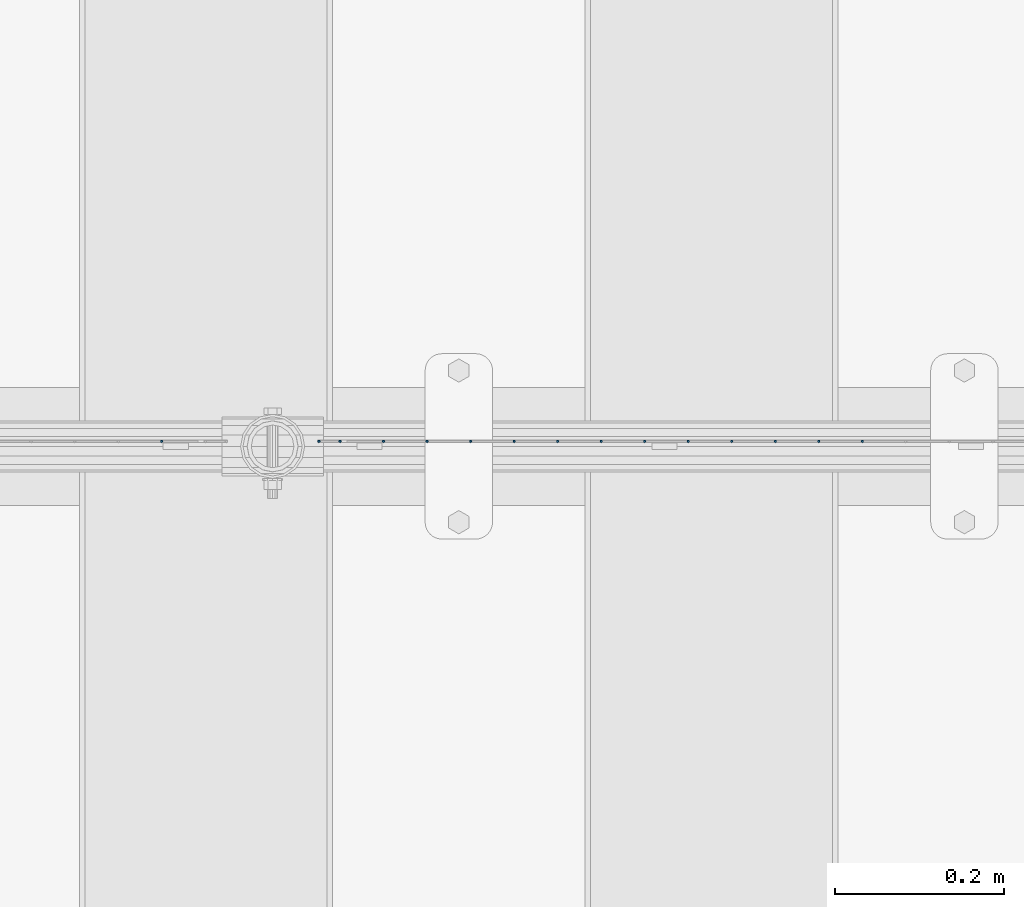
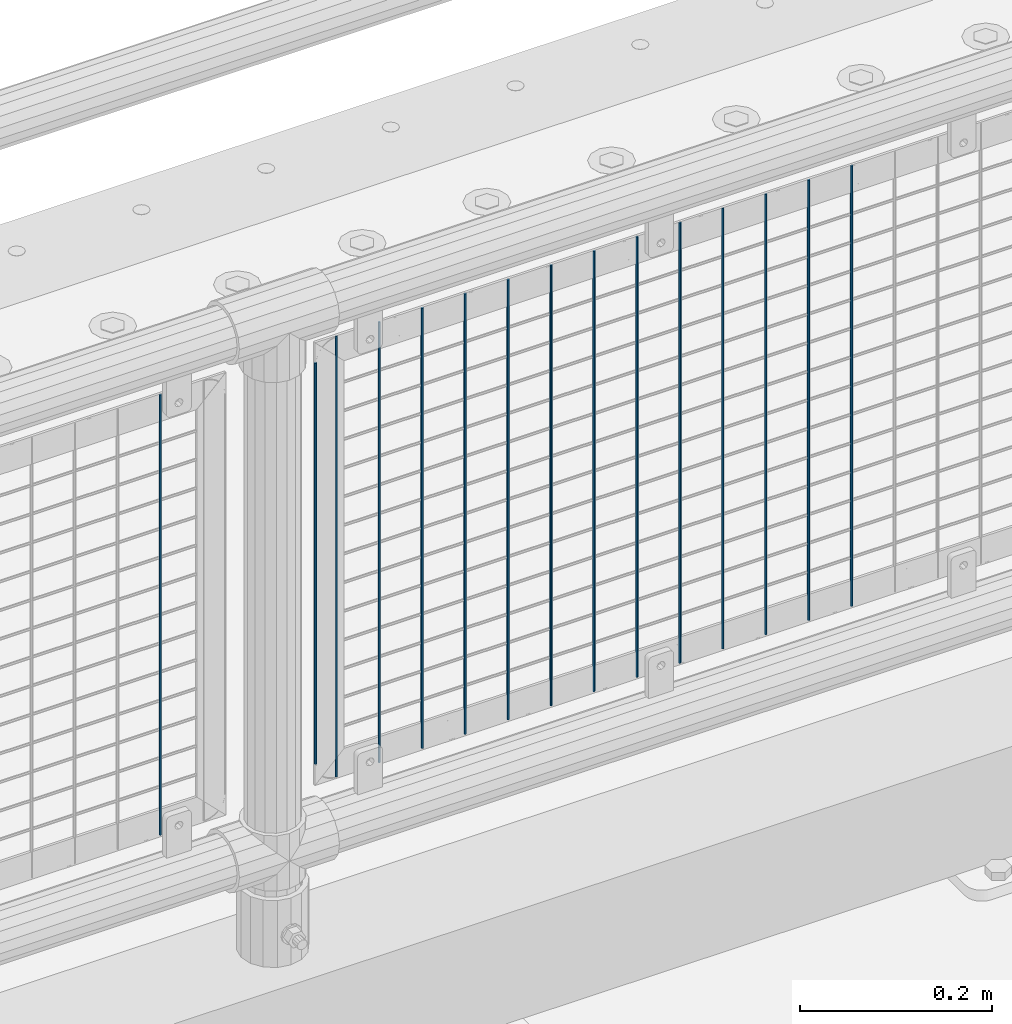
# One storey, part 67 of 219: 15 columns.
"""IFC2X3 building model written with IfcOpenShell, lengths in millimetres."""

from ifc_helpers import new_model, si_unit, frame, origin_with_axes, place, context, subcontext, project, spatial, faceted_brep, material, type_object, element, save


model = new_model("IFC2X3")

# Units and contexts
model_context = context("Model", 3, precision=1e-05, world=origin_with_axes())
body_context = subcontext(model_context, "Body", "Model", "MODEL_VIEW")
ifc_project = project(units=[si_unit("LENGTHUNIT", "METRE", prefix="MILLI"), si_unit("AREAUNIT", "SQUARE_METRE"), si_unit("VOLUMEUNIT", "CUBIC_METRE"), si_unit("MASSUNIT", "GRAM", prefix="KILO"), si_unit("TIMEUNIT", "SECOND"), si_unit("PLANEANGLEUNIT", "RADIAN"), si_unit("SOLIDANGLEUNIT", "STERADIAN"), si_unit("THERMODYNAMICTEMPERATUREUNIT", "DEGREE_CELSIUS"), si_unit("LUMINOUSINTENSITYUNIT", "LUMEN")], contexts=[model_context])

# Site, building, storey
site_placement = place(None, origin_with_axes())
site = spatial("IfcSite", under=ifc_project, at=site_placement, CompositionType="ELEMENT")
building_placement = place(site_placement, origin_with_axes())
building = spatial("IfcBuilding", under=site, at=building_placement, Name="Standard", CompositionType="ELEMENT")
storey_placement = place(building_placement, origin_with_axes())
storey = spatial("IfcBuildingStorey", under=building, at=storey_placement, Name="Undefined", CompositionType="ELEMENT", Elevation=0.0)

# Columns
ifc_material = material(Name="Misc_Undefined")
column_type = type_object("IfcColumnType", Name="D3", PredefinedType="NOTDEFINED")
for number, where, z_axis, x_axis in (
    (1, (2978.86, 31670.5, 353.02), (-1.0, 0.0, 0.0), (0.0, 0.0, 1.0)),
    (2, (2927.205, 31670.5, 353.02), (-1.0, 0.0, 0.0), (0.0, 0.0, 1.0)),
    (3, (2875.55, 31670.5, 353.02), (-1.0, 0.0, 0.0), (0.0, 0.0, 1.0)),
    (4, (2823.895, 31670.5, 353.02), (-1.0, 0.0, 0.0), (0.0, 0.0, 1.0)),
    (5, (2772.24, 31670.5, 353.02), (-1.0, 0.0, 0.0), (0.0, 0.0, 1.0)),
    (6, (2720.585, 31670.5, 353.02), (-1.0, 0.0, 0.0), (0.0, 0.0, 1.0)),
    (7, (2668.93, 31670.5, 353.02), (-1.0, 0.0, 0.0), (0.0, 0.0, 1.0)),
    (8, (2617.275, 31670.5, 353.02), (-1.0, 0.0, 0.0), (0.0, 0.0, 1.0)),
    (9, (2565.62, 31670.5, 353.02), (-1.0, 0.0, 0.0), (0.0, 0.0, 1.0)),
    (10, (2513.965, 31670.5, 353.02), (-1.0, 0.0, 0.0), (0.0, 0.0, 1.0)),
    (11, (2462.31, 31670.5, 353.02), (-1.0, 0.0, 0.0), (0.0, 0.0, 1.0)),
    (12, (2410.655, 31670.5, 353.02), (-1.0, 0.0, 0.0), (0.0, 0.0, 1.0)),
):
    element("IfcColumn", number, at=place(storey_placement, frame(where, z_axis=z_axis, x_axis=x_axis)), inside=storey, type_object=column_type, material=ifc_material, ObjectType="D3", context=body_context, shape_type="Brep", body=[
        faceted_brep([(0.0, -1.5, -5.6843418860808e-14), (0.0, -0.75, -1.29903810567669), (560.0, -0.75, -1.29903810567703), (560.0, -1.5, 0.0), (0.0, 0.75, -1.29903810567669), (560.0, 0.75, -1.29903810567703), (0.0, 1.5, -5.6843418860808e-14), (560.0, 1.5, 0.0), (0.0, 0.75, 1.29903810567669), (560.0, 0.75, 1.29903810567703), (0.0, -0.75, 1.29903810567669), (560.0, -0.75, 1.29903810567703)], [[[0, 1, 2, 3]], [[1, 4, 5, 2]], [[4, 6, 7, 5]], [[6, 8, 9, 7]], [[8, 10, 11, 9]], [[10, 0, 3, 11]], [[5, 7, 9, 11, 3, 2]], [[10, 8, 6, 4, 1, 0]]]),
    ])
column_placement = place(storey_placement, frame((2334.0, 31670.5, 378.02), z_axis=(-1.0, 0.0, 0.0), x_axis=(0.0, 0.0, 1.0)))
element("IfcColumn", 13, at=column_placement, inside=storey, type_object=column_type, material=ifc_material, ObjectType="D3", context=body_context, shape_type="Brep", body=[
    faceted_brep([(0.0, -1.5, -5.6843418860808e-14), (0.0, -0.75, -1.29903810567669), (510.0, -0.75, -1.29903810567703), (510.0, -1.5, 0.0), (0.0, 0.75, -1.29903810567669), (510.0, 0.75, -1.29903810567703), (0.0, 1.5, -5.6843418860808e-14), (510.0, 1.5, 0.0), (0.0, 0.75, 1.29903810567669), (510.0, 0.75, 1.29903810567703), (0.0, -0.75, 1.29903810567669), (510.0, -0.75, 1.29903810567703)], [[[0, 1, 2, 3]], [[1, 4, 5, 2]], [[4, 6, 7, 5]], [[6, 8, 9, 7]], [[8, 10, 11, 9]], [[10, 0, 3, 11]], [[5, 7, 9, 11, 3, 2]], [[10, 8, 6, 4, 1, 0]]]),
])
for number, where, z_axis, x_axis in (
    (14, (2359.0, 31670.5, 353.02), (-1.0, 0.0, 0.0), (0.0, 0.0, 1.0)),
    (15, (2147.34, 31670.5, 353.02), (-1.0, 0.0, 0.0), (0.0, 0.0, 1.0)),
):
    element("IfcColumn", number, at=place(storey_placement, frame(where, z_axis=z_axis, x_axis=x_axis)), inside=storey, type_object=column_type, material=ifc_material, ObjectType="D3", context=body_context, shape_type="Brep", body=[
        faceted_brep([(0.0, -1.5, -5.6843418860808e-14), (0.0, -0.75, -1.29903810567669), (560.0, -0.75, -1.29903810567703), (560.0, -1.5, 0.0), (0.0, 0.75, -1.29903810567669), (560.0, 0.75, -1.29903810567703), (0.0, 1.5, -5.6843418860808e-14), (560.0, 1.5, 0.0), (0.0, 0.75, 1.29903810567669), (560.0, 0.75, 1.29903810567703), (0.0, -0.75, 1.29903810567669), (560.0, -0.75, 1.29903810567703)], [[[0, 1, 2, 3]], [[1, 4, 5, 2]], [[4, 6, 7, 5]], [[6, 8, 9, 7]], [[8, 10, 11, 9]], [[10, 0, 3, 11]], [[5, 7, 9, 11, 3, 2]], [[10, 8, 6, 4, 1, 0]]]),
    ])

save(model, "model.ifc")
